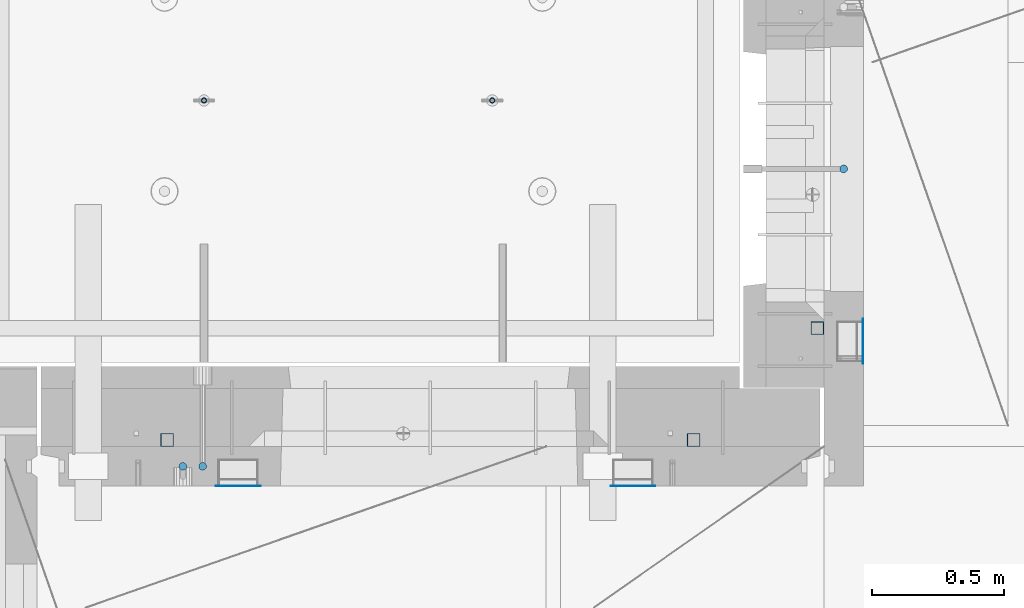
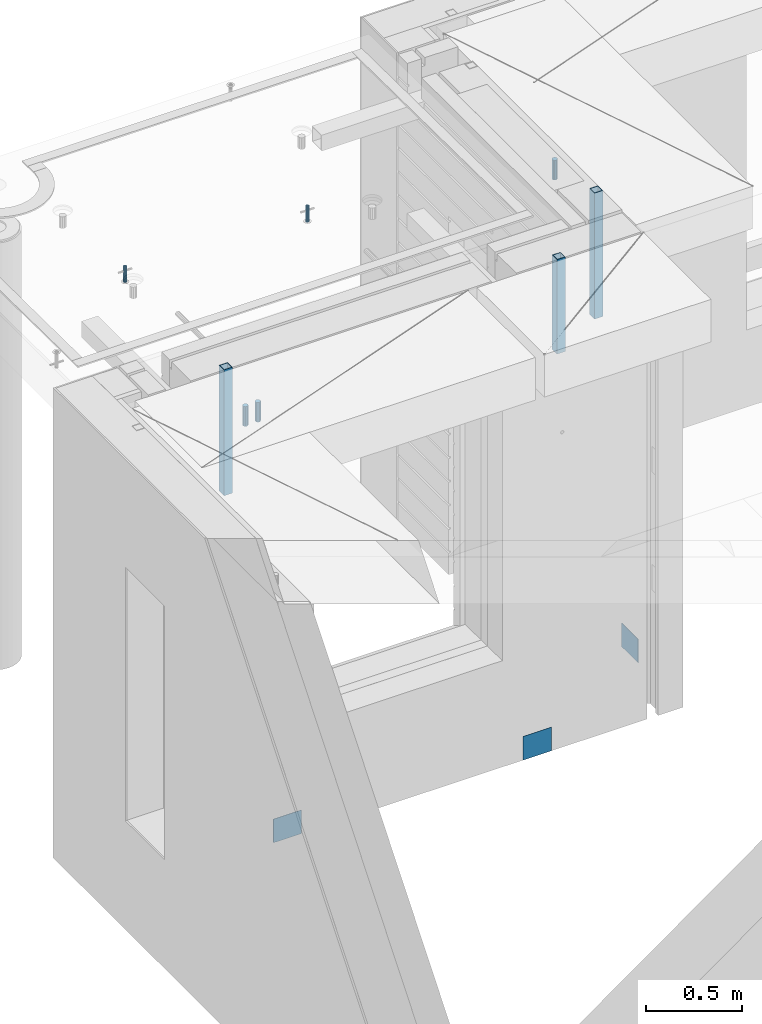
# One storey, part 26 of 341: 11 columns, 11 elements without a shape of their own.
"""IFC2X3 building model written with IfcOpenShell, lengths in millimetres."""

from ifc_helpers import new_model, si_unit, frame, origin_with_axes, place, context, subcontext, project, spatial, faceted_brep, material, type_object, element, aggregate, save


model = new_model("IFC2X3")

# Units and contexts
model_context = context("Model", 3, precision=1e-05, world=origin_with_axes())
body_context = subcontext(model_context, "Body", "Model", "MODEL_VIEW")
ifc_project = project(units=[si_unit("LENGTHUNIT", "METRE", prefix="MILLI"), si_unit("AREAUNIT", "SQUARE_METRE"), si_unit("VOLUMEUNIT", "CUBIC_METRE"), si_unit("MASSUNIT", "GRAM", prefix="KILO"), si_unit("TIMEUNIT", "SECOND"), si_unit("PLANEANGLEUNIT", "RADIAN"), si_unit("SOLIDANGLEUNIT", "STERADIAN"), si_unit("THERMODYNAMICTEMPERATUREUNIT", "DEGREE_CELSIUS"), si_unit("LUMINOUSINTENSITYUNIT", "LUMEN")], contexts=[model_context])

# Site, building, storey
site_placement = place(None, origin_with_axes())
site = spatial("IfcSite", under=ifc_project, at=site_placement, CompositionType="ELEMENT")
building_placement = place(site_placement, origin_with_axes())
building = spatial("IfcBuilding", under=site, at=building_placement, CompositionType="ELEMENT")
storey_placement = place(building_placement, origin_with_axes())
storey = spatial("IfcBuildingStorey", under=building, at=storey_placement, Name="5", CompositionType="ELEMENT", Elevation=0.0)

# Assembly, columns
assembly_1_placement = place(storey_placement, origin_with_axes())
assembly_1 = element("IfcElementAssembly", 1, at=assembly_1_placement, inside=storey, AssemblyPlace="NOTDEFINED", PredefinedType="REINFORCEMENT_UNIT")
ifc_material_1 = material()
column_type_1 = type_object("IfcColumnType", Name="D30", PredefinedType="NOTDEFINED")
column_1_placement = place(assembly_1_placement, frame((8555.00000000836, 20504.9951872276, 96407.5), z_axis=(0.0, 1.0, 0.0), x_axis=(0.0, 0.0, 1.0)))
column_1 = element("IfcColumn", 2, at=column_1_placement, type_object=column_type_1, material=ifc_material_1, ObjectType="D30", context=body_context, shape_type="Brep", body=[
    faceted_brep([(0.0, -15.0, 0.0), (0.0, -12.9903810567666, -7.5), (125.0, -12.9903810567666, -7.5), (125.0, -15.0, 0.0), (0.0, -7.5, -12.9903810567666), (125.0, -7.5, -12.9903810567666), (0.0, 0.0, -15.0), (125.0, 0.0, -15.0), (0.0, 7.5, -12.9903810567666), (125.0, 7.5, -12.9903810567666), (0.0, 12.9903810567666, -7.5), (125.0, 12.9903810567666, -7.5), (0.0, 15.0, 0.0), (125.0, 15.0, 0.0), (0.0, 12.9903810567666, 7.5), (125.0, 12.9903810567666, 7.5), (0.0, 7.5, 12.9903810567666), (125.0, 7.5, 12.9903810567666), (0.0, 0.0, 15.0), (125.0, 0.0, 15.0), (0.0, -7.5, 12.9903810567666), (125.0, -7.5, 12.9903810567666), (0.0, -12.9903810567666, 7.5), (125.0, -12.9903810567666, 7.5)], [[[0, 1, 2, 3]], [[1, 4, 5, 2]], [[4, 6, 7, 5]], [[6, 8, 9, 7]], [[8, 10, 11, 9]], [[10, 12, 13, 11]], [[12, 14, 15, 13]], [[14, 16, 17, 15]], [[16, 18, 19, 17]], [[18, 20, 21, 19]], [[20, 22, 23, 21]], [[22, 0, 3, 23]], [[5, 7, 9, 11, 13, 15, 17, 19, 21, 23, 3, 2]], [[22, 20, 18, 16, 14, 12, 10, 8, 6, 4, 1, 0]]]),
])
column_2_placement = place(assembly_1_placement, frame((8630.00733346229, 20504.9951872205, 96407.5), z_axis=(0.0, -1.0, 0.0), x_axis=(0.0, 0.0, 1.0)))
column_2 = element("IfcColumn", 3, at=column_2_placement, type_object=column_type_1, material=ifc_material_1, ObjectType="D30", context=body_context, shape_type="Brep", body=[
    faceted_brep([(0.0, -15.0, 0.0), (0.0, -12.9903810567666, -7.5), (125.0, -12.9903810567666, -7.5), (125.0, -15.0, 0.0), (0.0, -7.5, -12.9903810567666), (125.0, -7.5, -12.9903810567666), (0.0, 0.0, -15.0), (125.0, 0.0, -15.0), (0.0, 7.5, -12.9903810567666), (125.0, 7.5, -12.9903810567666), (0.0, 12.9903810567666, -7.5), (125.0, 12.9903810567666, -7.5), (0.0, 15.0, 0.0), (125.0, 15.0, 0.0), (0.0, 12.9903810567666, 7.5), (125.0, 12.9903810567666, 7.5), (0.0, 7.5, 12.9903810567666), (125.0, 7.5, 12.9903810567666), (0.0, 0.0, 15.0), (125.0, 0.0, 15.0), (0.0, -7.5, 12.9903810567666), (125.0, -7.5, 12.9903810567666), (0.0, -12.9903810567666, 7.5), (125.0, -12.9903810567666, 7.5)], [[[0, 1, 2, 3]], [[1, 4, 5, 2]], [[4, 6, 7, 5]], [[6, 8, 9, 7]], [[8, 10, 11, 9]], [[10, 12, 13, 11]], [[12, 14, 15, 13]], [[14, 16, 17, 15]], [[16, 18, 19, 17]], [[18, 20, 21, 19]], [[20, 22, 23, 21]], [[22, 0, 3, 23]], [[5, 7, 9, 11, 13, 15, 17, 19, 21, 23, 3, 2]], [[22, 20, 18, 16, 14, 12, 10, 8, 6, 4, 1, 0]]]),
])

# Assembly, column
assembly_2_placement = place(storey_placement, origin_with_axes())
assembly_2 = element("IfcElementAssembly", 4, at=assembly_2_placement, inside=storey, AssemblyPlace="NOTDEFINED", PredefinedType="REINFORCEMENT_UNIT")
column_3_placement = place(assembly_2_placement, frame((11064.9999999907, 21634.9982799657, 96407.5), z_axis=(1.0, 0.0, 0.0), x_axis=(0.0, 0.0, 1.0)))
column_3 = element("IfcColumn", 5, at=column_3_placement, type_object=column_type_1, material=ifc_material_1, ObjectType="D30", context=body_context, shape_type="Brep", body=[
    faceted_brep([(0.0, -15.0, 0.0), (0.0, -12.9903810567666, -7.5), (125.0, -12.9903810567666, -7.5), (125.0, -15.0, 0.0), (0.0, -7.5, -12.9903810567666), (125.0, -7.5, -12.9903810567666), (0.0, 0.0, -15.0), (125.0, 0.0, -15.0), (0.0, 7.5, -12.9903810567666), (125.0, 7.5, -12.9903810567666), (0.0, 12.9903810567666, -7.5), (125.0, 12.9903810567666, -7.5), (0.0, 15.0, 0.0), (125.0, 15.0, 0.0), (0.0, 12.9903810567666, 7.5), (125.0, 12.9903810567666, 7.5), (0.0, 7.5, 12.9903810567666), (125.0, 7.5, 12.9903810567666), (0.0, 0.0, 15.0), (125.0, 0.0, 15.0), (0.0, -7.5, 12.9903810567666), (125.0, -7.5, 12.9903810567666), (0.0, -12.9903810567666, 7.5), (125.0, -12.9903810567666, 7.5)], [[[0, 1, 2, 3]], [[1, 4, 5, 2]], [[4, 6, 7, 5]], [[6, 8, 9, 7]], [[8, 10, 11, 9]], [[10, 12, 13, 11]], [[12, 14, 15, 13]], [[14, 16, 17, 15]], [[16, 18, 19, 17]], [[18, 20, 21, 19]], [[20, 22, 23, 21]], [[22, 0, 3, 23]], [[5, 7, 9, 11, 13, 15, 17, 19, 21, 23, 3, 2]], [[22, 20, 18, 16, 14, 12, 10, 8, 6, 4, 1, 0]]]),
])

assembly_3_placement = place(assembly_1_placement, origin_with_axes())
assembly_3 = element("IfcElementAssembly", 6, at=assembly_3_placement, Name="Steel Assembly", AssemblyPlace="NOTDEFINED", PredefinedType="NOTDEFINED")
ifc_material_2 = material(Name="Undefined")
column_type_2 = type_object("IfcColumnType", PredefinedType="NOTDEFINED")
column_4_placement = place(assembly_3_placement, frame((10265.0, 20430.9951872214, 93755.0), z_axis=(0.0, -1.0, 0.0), x_axis=(0.0, 0.0, 1.0)))
column_4 = element("IfcColumn", 7, at=column_4_placement, type_object=column_type_2, material=ifc_material_2, Name="SPK2", context=body_context, shape_type="Brep", body=[
    faceted_brep([(0.0, 85.0, -1.0), (0.0, 85.0, 1.0), (150.0, 85.0, 1.0), (150.0, 85.0, -1.0), (0.0, -85.0, 1.0), (150.0, -85.0, 1.0), (0.0, -85.0, -1.0), (150.0, -85.0, -1.0)], [[[0, 1, 2, 3]], [[1, 4, 5, 2]], [[4, 6, 7, 5]], [[6, 0, 3, 7]], [[5, 7, 3, 2]], [[6, 4, 1, 0]]]),
])
aggregate(assembly_3, [column_4])

assembly_4_placement = place(assembly_1_placement, origin_with_axes())
assembly_4 = element("IfcElementAssembly", 8, at=assembly_4_placement, Name="Steel Assembly", AssemblyPlace="NOTDEFINED", PredefinedType="NOTDEFINED")
column_5_placement = place(assembly_4_placement, frame((8765.0, 20430.9951872214, 93755.0), z_axis=(0.0, -1.0, 0.0), x_axis=(0.0, 0.0, 1.0)))
column_5 = element("IfcColumn", 9, at=column_5_placement, type_object=column_type_2, material=ifc_material_2, Name="SPK2", context=body_context, shape_type="Brep", body=[
    faceted_brep([(0.0, 85.0, -1.0), (0.0, 85.0, 1.0), (150.0, 85.0, 1.0), (150.0, 85.0, -1.0), (0.0, -85.0, 1.0), (150.0, -85.0, 1.0), (0.0, -85.0, -1.0), (150.0, -85.0, -1.0)], [[[0, 1, 2, 3]], [[1, 4, 5, 2]], [[4, 6, 7, 5]], [[6, 0, 3, 7]], [[5, 7, 3, 2]], [[6, 4, 1, 0]]]),
])
aggregate(assembly_4, [column_5])

assembly_5_placement = place(assembly_2_placement, origin_with_axes())
assembly_5 = element("IfcElementAssembly", 10, at=assembly_5_placement, Name="Steel Assembly", AssemblyPlace="NOTDEFINED", PredefinedType="NOTDEFINED")
column_6_placement = place(assembly_5_placement, frame((11139.0000000031, 20979.9951872276, 93754.9999999969), z_axis=(1.0, 0.0, 0.0), x_axis=(0.0, 0.0, 1.0)))
column_6 = element("IfcColumn", 11, at=column_6_placement, type_object=column_type_2, material=ifc_material_2, Name="SPK2", context=body_context, shape_type="Brep", body=[
    faceted_brep([(0.0, 85.0, -1.0), (0.0, 85.0, 1.0), (150.0, 85.0, 1.0), (150.0, 85.0, -1.0), (0.0, -85.0, 1.0), (150.0, -85.0, 1.0), (0.0, -85.0, -1.0), (150.0, -85.0, -1.0)], [[[0, 1, 2, 3]], [[1, 4, 5, 2]], [[4, 6, 7, 5]], [[6, 0, 3, 7]], [[5, 7, 3, 2]], [[6, 4, 1, 0]]]),
])
aggregate(assembly_5, [column_6])

assembly_6_placement = place(assembly_1_placement, origin_with_axes())
assembly_6 = element("IfcElementAssembly", 12, at=assembly_6_placement, Name="Steel Assembly", AssemblyPlace="NOTDEFINED", PredefinedType="RIGID_FRAME")
ifc_material_3 = material(Name="STEEL/S355J2")
column_type_3 = type_object("IfcColumnType", Name="50X50X3", PredefinedType="NOTDEFINED")
column_7_placement = place(assembly_6_placement, frame((8495.0, 20605.0, 95940.0), z_axis=(1.0, 0.0, 0.0), x_axis=(0.0, 0.0, 1.0)))
column_7 = element("IfcColumn", 13, at=column_7_placement, type_object=column_type_3, material=ifc_material_3, ObjectType="50X50X3", context=body_context, shape_type="Brep", body=[
    faceted_brep([(0.0, 22.0, -22.0), (0.0, -22.0, -22.0), (800.0, -22.0, -22.0), (800.0, 22.0, -22.0), (0.0, -22.0, 22.0), (800.0, -22.0, 22.0), (0.0, 22.0, 22.0), (800.0, 22.0, 22.0), (0.0, 25.0, -25.0), (0.0, 25.0, 25.0), (800.0, 25.0, 25.0), (800.0, 25.0, -25.0), (0.0, -25.0, 25.0), (800.0, -25.0, 25.0), (0.0, -25.0, -25.0), (800.0, -25.0, -25.0)], [[[0, 1, 2, 3]], [[1, 4, 5, 2]], [[4, 6, 7, 5]], [[6, 0, 3, 7]], [[8, 9, 10, 11]], [[9, 12, 13, 10]], [[12, 14, 15, 13]], [[14, 8, 11, 15]], [[13, 15, 11, 10], [5, 7, 3, 2]], [[14, 12, 9, 8], [6, 4, 1, 0]]]),
])
aggregate(assembly_6, [column_7])

# Assembly
assembly_7_placement = place(assembly_1_placement, origin_with_axes())
assembly_7 = element("IfcElementAssembly", 14, at=assembly_7_placement, Name="Steel Assembly", AssemblyPlace="NOTDEFINED", PredefinedType="RIGID_FRAME")

aggregate(assembly_1, [column_1, column_2, assembly_3, assembly_4, assembly_6, assembly_7])

# Column
column_8_placement = place(assembly_7_placement, frame((10495.0, 20605.0, 96140.0), z_axis=(1.0, 0.0, 0.0), x_axis=(0.0, 0.0, 1.0)))
column_8 = element("IfcColumn", 15, at=column_8_placement, type_object=column_type_3, material=ifc_material_3, ObjectType="50X50X3", context=body_context, shape_type="Brep", body=[
    faceted_brep([(0.0, 22.0, -22.0), (0.0, -22.0, -22.0), (600.0, -22.0, -22.0), (600.0, 22.0, -22.0), (0.0, -22.0, 22.0), (600.0, -22.0, 22.0), (0.0, 22.0, 22.0), (600.0, 22.0, 22.0), (0.0, 25.0, -25.0), (0.0, 25.0, 25.0), (600.0, 25.0, 25.0), (600.0, 25.0, -25.0), (0.0, -25.0, 25.0), (600.0, -25.0, 25.0), (0.0, -25.0, -25.0), (600.0, -25.0, -25.0)], [[[0, 1, 2, 3]], [[1, 4, 5, 2]], [[4, 6, 7, 5]], [[6, 0, 3, 7]], [[8, 9, 10, 11]], [[9, 12, 13, 10]], [[12, 14, 15, 13]], [[14, 8, 11, 15]], [[13, 15, 11, 10], [5, 7, 3, 2]], [[14, 12, 9, 8], [6, 4, 1, 0]]]),
])

aggregate(assembly_7, [column_8])

# Assembly
assembly_8_placement = place(assembly_2_placement, origin_with_axes())
assembly_8 = element("IfcElementAssembly", 16, at=assembly_8_placement, Name="Steel Assembly", AssemblyPlace="NOTDEFINED", PredefinedType="RIGID_FRAME")

aggregate(assembly_2, [column_3, assembly_5, assembly_8])

# Column
column_9_placement = place(assembly_8_placement, frame((10965.0, 21030.0, 95940.0), z_axis=(1.0, 0.0, 0.0), x_axis=(0.0, 0.0, 1.0)))
column_9 = element("IfcColumn", 17, at=column_9_placement, type_object=column_type_3, material=ifc_material_3, ObjectType="50X50X3", context=body_context, shape_type="Brep", body=[
    faceted_brep([(0.0, 22.0, -22.0), (0.0, -22.0, -22.0), (800.0, -22.0, -22.0), (800.0, 22.0, -22.0), (0.0, -22.0, 22.0), (800.0, -22.0, 22.0), (0.0, 22.0, 22.0), (800.0, 22.0, 22.0), (0.0, 25.0, -25.0), (0.0, 25.0, 25.0), (800.0, 25.0, 25.0), (800.0, 25.0, -25.0), (0.0, -25.0, 25.0), (800.0, -25.0, 25.0), (0.0, -25.0, -25.0), (800.0, -25.0, -25.0)], [[[0, 1, 2, 3]], [[1, 4, 5, 2]], [[4, 6, 7, 5]], [[6, 0, 3, 7]], [[8, 9, 10, 11]], [[9, 12, 13, 10]], [[12, 14, 15, 13]], [[14, 8, 11, 15]], [[13, 15, 11, 10], [5, 7, 3, 2]], [[14, 12, 9, 8], [6, 4, 1, 0]]]),
])

aggregate(assembly_8, [column_9])

# Assemblies, columns
assembly_9_placement = place(storey_placement, origin_with_axes())
assembly_9 = element("IfcElementAssembly", 18, at=assembly_9_placement, inside=storey, AssemblyPlace="NOTDEFINED", PredefinedType="REINFORCEMENT_UNIT")
assembly_10_placement = place(assembly_9_placement, origin_with_axes())
assembly_10 = element("IfcElementAssembly", 19, at=assembly_10_placement, Name="Steel Assembly", AssemblyPlace="NOTDEFINED", PredefinedType="RIGID_FRAME")
ifc_material_4 = material(Name="STEEL/1.4301")
column_type_4 = type_object("IfcColumnType", PredefinedType="NOTDEFINED")
column_10_placement = place(assembly_10_placement, frame((8634.9865866494, 21895.0212615308, 96444.9999983246), z_axis=(-1.60829999983552e-05, -0.999999999870669, 0.0), x_axis=(0.0, 0.0, 1.0)))
column_10 = element("IfcColumn", 20, at=column_10_placement, type_object=column_type_4, material=ifc_material_4, context=body_context, shape_type="Brep", body=[
    faceted_brep([(0.0, -8.0, 0.0), (0.0, -6.92820323027263, 4.0), (100.000000000029, -6.92820323027263, 4.0), (100.000000000029, -7.99999999999636, 0.0), (0.0, -4.0, 6.92820323027627), (100.000000000029, -4.0, 6.92820323027536), (0.0, 0.0, 8.0), (100.000000000029, 3.63797880709171e-12, 8.0), (0.0, 4.0, 6.92820323027627), (100.000000000029, 4.0, 6.92820323027536), (0.0, 6.92820323027263, 4.0), (100.000000000029, 6.92820323027627, 3.99999999999909), (0.0, 8.0, 0.0), (100.000000000029, 8.0, 0.0), (0.0, 6.92820323027263, -4.0), (100.000000000029, 6.92820323027627, -4.00000000000091), (0.0, 4.0, -6.92820323027627), (100.000000000029, 4.00000000000364, -6.92820323027536), (0.0, 0.0, -8.0), (100.000000000029, 3.63797880709171e-12, -8.00000000000091), (0.0, -4.0, -6.92820323027627), (100.000000000029, -3.99999999999636, -6.92820323027627), (0.0, -6.92820323027263, -4.0), (100.000000000029, -6.92820323027263, -4.0), (0.0, -10.4999999999927, -1.45519152283669e-11), (0.0, -9.09326673972828, -5.25000000001455), (100.000000000262, -9.09326673972828, -5.25000000001455), (100.000000000262, -10.4999999999927, -1.45519152283669e-11), (0.0, -5.24999999998545, -9.09326673974283), (100.000000000262, -5.24999999998545, -9.09326673974283), (0.0, 7.27595761418343e-12, -10.5), (100.000000000262, 7.27595761418343e-12, -10.5), (0.0, 5.25000000001455, -9.09326673975738), (100.000000000262, 5.25000000001455, -9.09326673975738), (0.0, 9.09326673975011, -5.25000000001455), (100.000000000262, 9.09326673975011, -5.25000000001455), (0.0, 10.5000000000073, -1.45519152283669e-11), (100.000000000262, 10.5000000000073, -1.45519152283669e-11), (0.0, 9.09326673975011, 5.25), (100.000000000262, 9.09326673975011, 5.25), (0.0, 5.25000000000728, 9.09326673972828), (100.000000000262, 5.25000000000728, 9.09326673972828), (0.0, 1.45519152283669e-11, 10.4999999999854), (100.000000000262, 1.45519152283669e-11, 10.4999999999854), (0.0, -5.24999999999272, 9.09326673972828), (100.000000000262, -5.24999999999272, 9.09326673972828), (0.0, -9.09326673972828, 5.24999999998545), (100.000000000262, -9.09326673972828, 5.24999999998545)], [[[0, 1, 2, 3]], [[1, 4, 5, 2]], [[4, 6, 7, 5]], [[6, 8, 9, 7]], [[8, 10, 11, 9]], [[10, 12, 13, 11]], [[12, 14, 15, 13]], [[14, 16, 17, 15]], [[16, 18, 19, 17]], [[18, 20, 21, 19]], [[20, 22, 23, 21]], [[22, 0, 3, 23]], [[24, 25, 26, 27]], [[25, 28, 29, 26]], [[28, 30, 31, 29]], [[30, 32, 33, 31]], [[32, 34, 35, 33]], [[34, 36, 37, 35]], [[36, 38, 39, 37]], [[38, 40, 41, 39]], [[40, 42, 43, 41]], [[42, 44, 45, 43]], [[44, 46, 47, 45]], [[46, 24, 27, 47]], [[29, 31, 33, 35, 37, 39, 41, 43, 45, 47, 27, 26], [5, 7, 9, 11, 13, 15, 17, 19, 21, 23, 3, 2]], [[46, 44, 42, 40, 38, 36, 34, 32, 30, 28, 25, 24], [22, 20, 18, 16, 14, 12, 10, 8, 6, 4, 1, 0]]]),
])
aggregate(assembly_10, [column_10])
assembly_11_placement = place(assembly_9_placement, origin_with_axes())
assembly_11 = element("IfcElementAssembly", 21, at=assembly_11_placement, Name="Steel Assembly", AssemblyPlace="NOTDEFINED", PredefinedType="RIGID_FRAME")
aggregate(assembly_9, [assembly_10, assembly_11])
column_11_placement = place(assembly_11_placement, frame((9729.98658651215, 21895.0041915483, 96444.9999983246), z_axis=(-1.60829999983552e-05, -0.999999999870669, 0.0), x_axis=(0.0, 0.0, 1.0)))
column_11 = element("IfcColumn", 22, at=column_11_placement, type_object=column_type_4, material=ifc_material_4, context=body_context, shape_type="Brep", body=[
    faceted_brep([(0.0, -8.0, 0.0), (0.0, -6.92820323027263, 4.0), (100.000000000029, -6.92820323027263, 4.0), (100.000000000029, -7.99999999999636, 0.0), (0.0, -4.0, 6.92820323027627), (100.000000000029, -4.0, 6.92820323027536), (0.0, 0.0, 8.0), (100.000000000029, 3.63797880709171e-12, 8.0), (0.0, 4.0, 6.92820323027627), (100.000000000029, 4.0, 6.92820323027536), (0.0, 6.92820323027263, 4.0), (100.000000000029, 6.92820323027627, 3.99999999999909), (0.0, 8.0, 0.0), (100.000000000029, 8.0, 0.0), (0.0, 6.92820323027263, -4.0), (100.000000000029, 6.92820323027627, -4.00000000000091), (0.0, 4.0, -6.92820323027627), (100.000000000029, 4.00000000000364, -6.92820323027536), (0.0, 0.0, -8.0), (100.000000000029, 3.63797880709171e-12, -8.00000000000091), (0.0, -4.0, -6.92820323027627), (100.000000000029, -3.99999999999636, -6.92820323027627), (0.0, -6.92820323027263, -4.0), (100.000000000029, -6.92820323027263, -4.0), (0.0, -10.4999999999927, -1.45519152283669e-11), (0.0, -9.09326673972828, -5.25000000001455), (100.000000000262, -9.09326673972828, -5.25000000001455), (100.000000000262, -10.4999999999927, -1.45519152283669e-11), (0.0, -5.24999999998545, -9.09326673974283), (100.000000000262, -5.24999999998545, -9.09326673974283), (0.0, 7.27595761418343e-12, -10.5), (100.000000000262, 7.27595761418343e-12, -10.5), (0.0, 5.25000000001455, -9.09326673975738), (100.000000000262, 5.25000000001455, -9.09326673975738), (0.0, 9.09326673975011, -5.25000000001455), (100.000000000262, 9.09326673975011, -5.25000000001455), (0.0, 10.5000000000073, -1.45519152283669e-11), (100.000000000262, 10.5000000000073, -1.45519152283669e-11), (0.0, 9.09326673975011, 5.25), (100.000000000262, 9.09326673975011, 5.25), (0.0, 5.25000000000728, 9.09326673972828), (100.000000000262, 5.25000000000728, 9.09326673972828), (0.0, 1.45519152283669e-11, 10.4999999999854), (100.000000000262, 1.45519152283669e-11, 10.4999999999854), (0.0, -5.24999999999272, 9.09326673972828), (100.000000000262, -5.24999999999272, 9.09326673972828), (0.0, -9.09326673972828, 5.24999999998545), (100.000000000262, -9.09326673972828, 5.24999999998545)], [[[0, 1, 2, 3]], [[1, 4, 5, 2]], [[4, 6, 7, 5]], [[6, 8, 9, 7]], [[8, 10, 11, 9]], [[10, 12, 13, 11]], [[12, 14, 15, 13]], [[14, 16, 17, 15]], [[16, 18, 19, 17]], [[18, 20, 21, 19]], [[20, 22, 23, 21]], [[22, 0, 3, 23]], [[24, 25, 26, 27]], [[25, 28, 29, 26]], [[28, 30, 31, 29]], [[30, 32, 33, 31]], [[32, 34, 35, 33]], [[34, 36, 37, 35]], [[36, 38, 39, 37]], [[38, 40, 41, 39]], [[40, 42, 43, 41]], [[42, 44, 45, 43]], [[44, 46, 47, 45]], [[46, 24, 27, 47]], [[29, 31, 33, 35, 37, 39, 41, 43, 45, 47, 27, 26], [5, 7, 9, 11, 13, 15, 17, 19, 21, 23, 3, 2]], [[46, 44, 42, 40, 38, 36, 34, 32, 30, 28, 25, 24], [22, 20, 18, 16, 14, 12, 10, 8, 6, 4, 1, 0]]]),
])
aggregate(assembly_11, [column_11])

save(model, "model.ifc")
